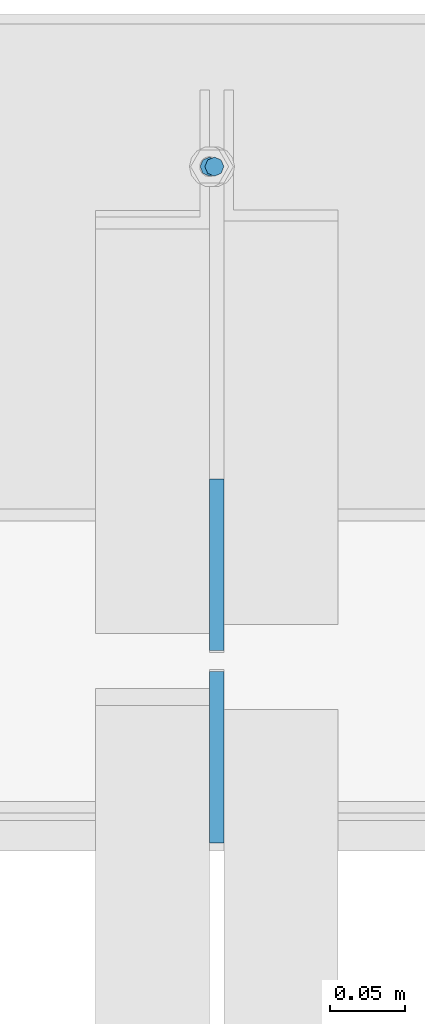
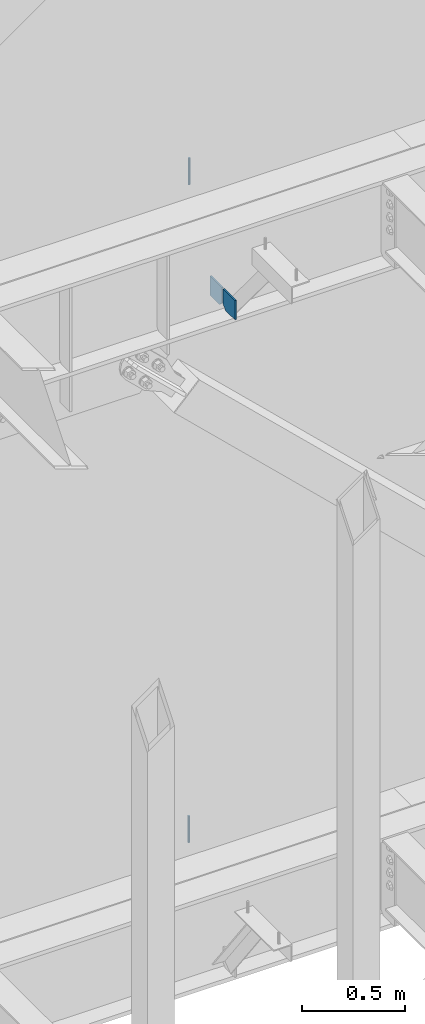
# One storey, part 581 of 1179: 4 columns, 2 elements without a shape of their own.
"""IFC2X3 building model written with IfcOpenShell, lengths in millimetres."""

from ifc_helpers import new_model, si_unit, frame, origin_with_axes, place, context, subcontext, project, spatial, faceted_brep, material, type_object, element, aggregate, save


model = new_model("IFC2X3")

# Units and contexts
model_context = context("Model", 3, precision=1e-05, world=origin_with_axes())
body_context = subcontext(model_context, "Body", "Model", "MODEL_VIEW")
ifc_project = project(units=[si_unit("LENGTHUNIT", "METRE", prefix="MILLI"), si_unit("AREAUNIT", "SQUARE_METRE"), si_unit("VOLUMEUNIT", "CUBIC_METRE"), si_unit("MASSUNIT", "GRAM", prefix="KILO"), si_unit("TIMEUNIT", "SECOND"), si_unit("PLANEANGLEUNIT", "RADIAN"), si_unit("SOLIDANGLEUNIT", "STERADIAN"), si_unit("THERMODYNAMICTEMPERATUREUNIT", "DEGREE_CELSIUS"), si_unit("LUMINOUSINTENSITYUNIT", "LUMEN")], contexts=[model_context])

# Site, building, storey
site_placement = place(None, origin_with_axes())
site = spatial("IfcSite", under=ifc_project, at=site_placement, CompositionType="ELEMENT")
building_placement = place(site_placement, origin_with_axes())
building = spatial("IfcBuilding", under=site, at=building_placement, Name="Undefined", CompositionType="ELEMENT")
storey_placement = place(building_placement, origin_with_axes())
storey = spatial("IfcBuildingStorey", under=building, at=storey_placement, Name="Undefined", CompositionType="ELEMENT", Elevation=0.0)

# Assembly, columns
assembly_1_placement = place(storey_placement, origin_with_axes())
assembly_1 = element("IfcElementAssembly", 1, at=assembly_1_placement, inside=storey, Name="BEAM", AssemblyPlace="NOTDEFINED", PredefinedType="RIGID_FRAME")
ifc_material_1 = material(Name="STEEL/A36")
column_type_1 = type_object("IfcColumnType", PredefinedType="NOTDEFINED")
column_1_placement = place(assembly_1_placement, frame((13288.9625, 41263.09375, 7488.2375), z_axis=(0.0, -1.0, 0.0), x_axis=(0.0, 0.0, 1.0)))
column_1 = element("IfcColumn", 2, at=column_1_placement, type_object=column_type_1, material=ifc_material_1, Name="PLATE", context=body_context, shape_type="Brep", body=[
    faceted_brep([(22.2250000000004, 4.76250000000073, 57.1500000000015), (0.0, 4.76250000000073, 34.9249999999993), (0.0, -4.76250000000073, 34.9249999999993), (22.2250000000004, -4.76250000000073, 57.1500000000015), (114.300000000001, 4.76250000000073, 57.1500000000015), (114.300000000001, 4.76250000000073, -57.1500000000015), (0.0, 4.76250000000073, -57.1500000000015), (114.300000000001, -4.76250000000073, 57.1500000000015), (0.0, -4.76250000000073, -57.1500000000015), (114.300000000001, -4.76250000000073, -57.1500000000015)], [[[0, 1, 2, 3]], [[4, 5, 6, 1, 0]], [[7, 4, 0, 3]], [[8, 9, 7, 3, 2]], [[8, 6, 5, 9]], [[7, 9, 5, 4]], [[6, 8, 2, 1]]]),
])
column_2_placement = place(assembly_1_placement, frame((13288.9625, 41134.50625, 7488.2375), z_axis=(0.0, 1.0, 0.0), x_axis=(0.0, 0.0, 1.0)))
column_2 = element("IfcColumn", 3, at=column_2_placement, type_object=column_type_1, material=ifc_material_1, Name="PLATE", context=body_context, shape_type="Brep", body=[
    faceted_brep([(22.2250000000004, 4.76250000000073, 57.1500000000015), (0.0, 4.76250000000073, 34.9249999999993), (0.0, -4.76250000000073, 34.9249999999993), (22.2250000000004, -4.76250000000073, 57.1500000000015), (114.300000000001, 4.76250000000073, 57.1500000000015), (114.300000000001, 4.76250000000073, -57.1500000000015), (0.0, 4.76250000000073, -57.1500000000015), (114.300000000001, -4.76250000000073, 57.1500000000015), (0.0, -4.76250000000073, -57.1500000000015), (114.300000000001, -4.76250000000073, -57.1500000000015)], [[[0, 1, 2, 3]], [[4, 5, 6, 1, 0]], [[7, 4, 0, 3]], [[8, 9, 7, 3, 2]], [[8, 6, 5, 9]], [[7, 9, 5, 4]], [[6, 8, 2, 1]]]),
])
ifc_material_2 = material(Name="STEEL/A307")
column_type_2 = type_object("IfcColumnType", PredefinedType="NOTDEFINED")
column_3_placement = place(assembly_1_placement, frame((13287.375, 41529.0, 8020.05), z_axis=(0.0, 1.0, 0.0), x_axis=(0.0, 0.0, 1.0)))
column_3 = element("IfcColumn", 4, at=column_3_placement, type_object=column_type_2, material=ifc_material_2, Name="THREADED ROD", context=body_context, shape_type="Brep", body=[
    faceted_brep([(0.0, -6.34999999999854, 0.0), (0.0, -4.49012806053361, -4.49012806053452), (157.162499999999, -4.49012806053361, -4.49012806053361), (157.162499999999, -6.34999999999854, 0.0), (0.0, 0.0, -6.34999999999991), (157.162499999999, 0.0, -6.34999999999854), (0.0, 4.49012806053361, -4.49012806053452), (157.162499999999, 4.49012806053361, -4.49012806053361), (0.0, 6.34999999999854, 0.0), (157.162499999999, 6.34999999999854, 0.0), (0.0, 4.49012806053361, 4.49012806053452), (157.162499999999, 4.49012806053361, 4.49012806053361), (0.0, 0.0, 6.34999999999991), (157.162499999999, 0.0, 6.34999999999854), (0.0, -4.49012806053361, 4.49012806053452), (157.162499999999, -4.49012806053361, 4.49012806053361)], [[[0, 1, 2, 3]], [[1, 4, 5, 2]], [[4, 6, 7, 5]], [[6, 8, 9, 7]], [[8, 10, 11, 9]], [[10, 12, 13, 11]], [[12, 14, 15, 13]], [[14, 0, 3, 15]], [[5, 7, 9, 11, 13, 15, 3, 2]], [[14, 12, 10, 8, 6, 4, 1, 0]]]),
])
aggregate(assembly_1, [column_3, column_1, column_2])

# Assembly, column
assembly_2_placement = place(storey_placement, origin_with_axes())
assembly_2 = element("IfcElementAssembly", 5, at=assembly_2_placement, inside=storey, Name="BEAM", AssemblyPlace="NOTDEFINED", PredefinedType="RIGID_FRAME")
column_4_placement = place(assembly_2_placement, frame((13284.1999938965, 41529.0, 4108.45), z_axis=(0.0, 1.0, 0.0), x_axis=(0.0, 0.0, 1.0)))
column_4 = element("IfcColumn", 6, at=column_4_placement, type_object=column_type_2, material=ifc_material_2, Name="THREADED ROD", context=body_context, shape_type="Brep", body=[
    faceted_brep([(0.0, -6.34999999999854, 0.0), (0.0, -4.49012806053361, -4.49012806053452), (157.162499999999, -4.49012806053361, -4.49012806053361), (157.162499999999, -6.34999999999854, 0.0), (0.0, 0.0, -6.34999999999991), (157.162499999999, 0.0, -6.34999999999854), (0.0, 4.49012806053361, -4.49012806053452), (157.162499999999, 4.49012806053361, -4.49012806053361), (0.0, 6.34999999999854, 0.0), (157.162499999999, 6.34999999999854, 0.0), (0.0, 4.49012806053361, 4.49012806053452), (157.162499999999, 4.49012806053361, 4.49012806053361), (0.0, 0.0, 6.34999999999991), (157.162499999999, 0.0, 6.34999999999854), (0.0, -4.49012806053361, 4.49012806053452), (157.162499999999, -4.49012806053361, 4.49012806053361)], [[[0, 1, 2, 3]], [[1, 4, 5, 2]], [[4, 6, 7, 5]], [[6, 8, 9, 7]], [[8, 10, 11, 9]], [[10, 12, 13, 11]], [[12, 14, 15, 13]], [[14, 0, 3, 15]], [[5, 7, 9, 11, 13, 15, 3, 2]], [[14, 12, 10, 8, 6, 4, 1, 0]]]),
])
aggregate(assembly_2, [column_4])

save(model, "model.ifc")
